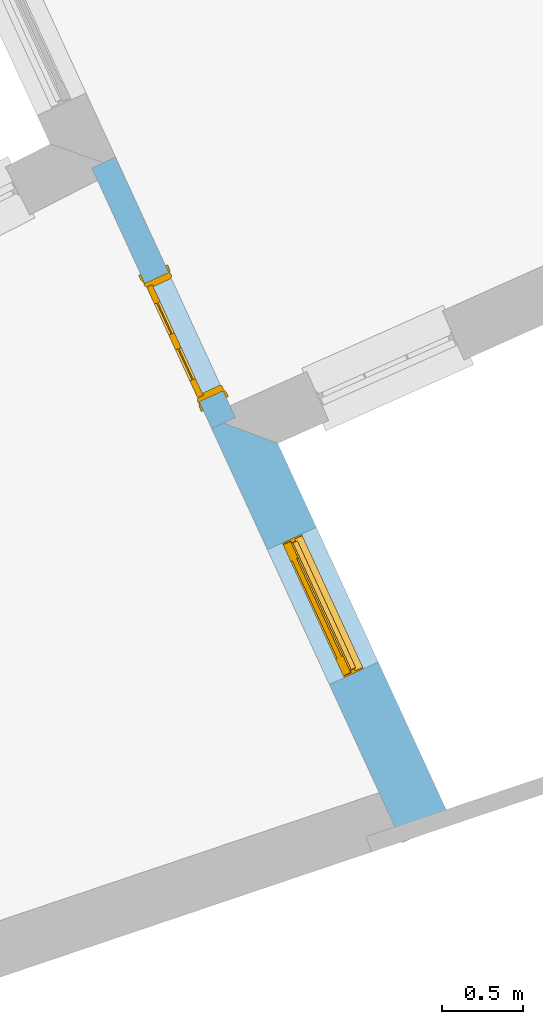
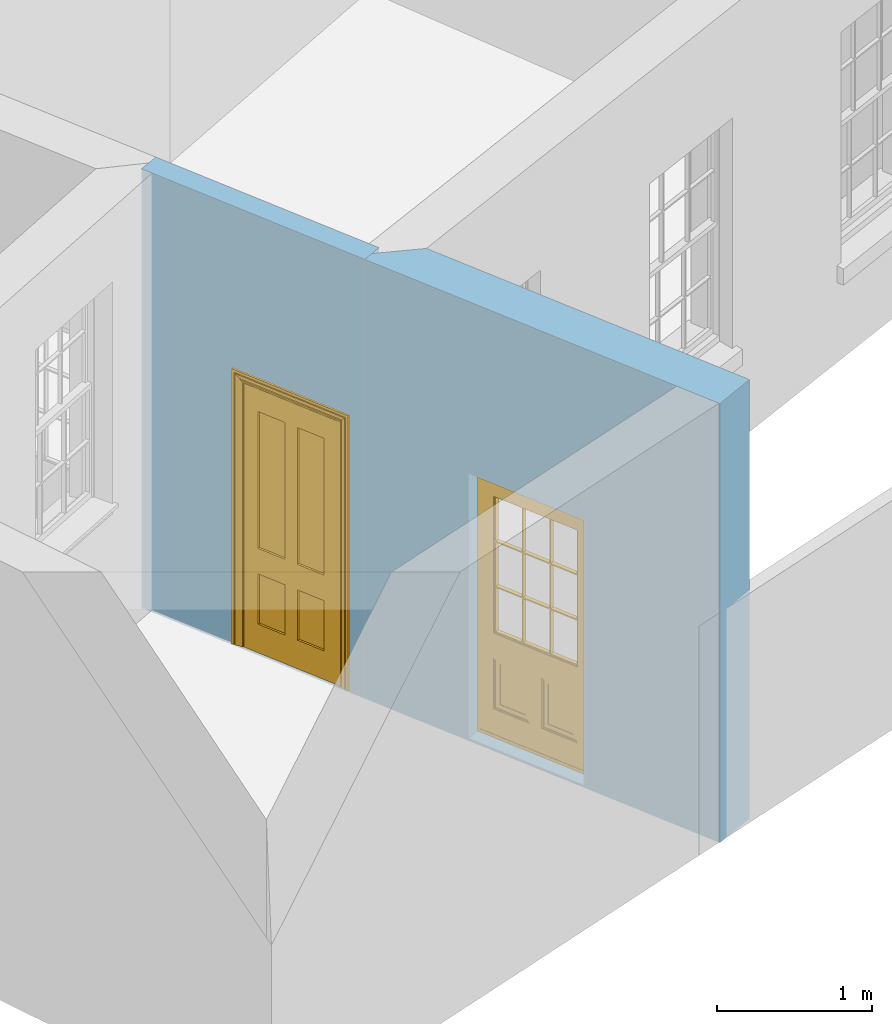
# One storey, part 3 of 10: 2 doors, 2 openings, plus 2 elements that do not belong to this part.
"""IFC2X3 building model written with IfcOpenShell, lengths in metres."""

from ifc_helpers import new_model, si_unit, frame, origin, place, context, subcontext, project, spatial, polyline, outline, extrude, faceted_brep, material, layer, layer_set, layer_usage, element, fill, save


model = new_model("IFC2X3")

# Units and contexts
model_context = context("Model", 3, world=origin())
body_context = subcontext(model_context, "Body", "Model", "MODEL_VIEW")
ifc_project = project(units=[si_unit("PLANEANGLEUNIT", "RADIAN"), si_unit("MASSUNIT", "GRAM", prefix="KILO"), si_unit("FORCEUNIT", "NEWTON", prefix="KILO"), si_unit("LENGTHUNIT", "METRE")], contexts=[model_context])

# Site, building, storey
site_placement = place(None, origin())
site = spatial("IfcSite", under=ifc_project, at=site_placement, CompositionType="ELEMENT")
building_placement = place(None, origin())
building = spatial("IfcBuilding", under=site, at=building_placement, Name="Building plot-8", CompositionType="ELEMENT")
storey_placement = place(None, origin())
storey = spatial("IfcBuildingStorey", under=building, at=storey_placement, Name="Floor 0", CompositionType="ELEMENT", Elevation=0.0)

# Wall, opening, door
ifc_material_1 = material(Name="Masonry")
ifc_layer_1 = layer(ifc_material_1, 0.33, ventilated=False)
ifc_layer_set_1 = layer_set([ifc_layer_1], Name="My Wall")
ifc_layer_usage_1 = layer_usage(ifc_layer_set_1, "AXIS2", "NEGATIVE", 0.08)
wall_1_placement = place(storey_placement, origin())
wall_1 = element("IfcWallStandardCase", 1, at=wall_1_placement, inside=storey, material=ifc_layer_usage_1, Name="exterior", context=body_context, shape_type="SweptSolid", body=[
    extrude(outline(polyline([(26.7463189204902, 6.45280484121041), (27.0461218313343, 6.59071138438159), (25.9819110894624, 8.90425989939787), (25.5427100949966, 9.06939881204675), (26.7463189204902, 6.45280484121041)])), origin(), (0.0, 0.0, 1.0), 3.45),
])
opening_1_placement = place(storey_placement, frame((0.0, 0.0, 0.02)))
opening_1 = element("IfcOpeningElement", 2, at=opening_1_placement, cuts=wall_1, Name="Opening", ObjectType="Opening", context=body_context, shape_type="SweptSolid", body=[
    extrude(outline(polyline([(26.5991206991673, 7.56247267643206), (26.2188329589074, 8.3892019154263), (25.9190300480633, 8.25129537225511), (26.2993177883233, 7.42456613326087), (26.5991206991673, 7.56247267643206)])), origin(), (0.0, 0.0, 1.0), 2.08),
])
door_1_placement = place(storey_placement, frame((26.3719972818612, 7.4579980225145, 0.02), z_axis=(0.0, 0.0, 1.0), x_axis=(-0.380287740259931, 0.82672923899424, 0.0)))
door_1 = element("IfcDoor", 3, at=door_1_placement, inside=storey, Name="kitchen door", OverallHeight=2.08, OverallWidth=0.91, context=body_context, shape_type="Brep", held_by="IfcProductRepresentation", body=[
    faceted_brep([(0.545, -0.055, 0.265), (0.745, -0.055, 0.265), (0.745, -0.05, 0.265), (0.545, -0.05, 0.265), (0.745, -0.05, 0.58), (0.545, -0.05, 0.58), (0.545, -0.055, 0.58), (0.515, -0.06, 0.235), (0.775, -0.06, 0.235), (0.745, -0.055, 0.58), (0.515, -0.06, 0.61), (0.515, -0.065, 0.235), (0.775, -0.065, 0.235), (0.775, -0.06, 0.61), (0.515, -0.065, 0.61), (0.785, -0.065, 0.225), (0.505, -0.065, 0.225), (0.775, -0.065, 0.61), (0.505, -0.065, 0.62), (0.785, -0.065, 0.62), (0.505, -0.07, 0.225), (0.785, -0.07, 0.225), (0.505, -0.07, 0.62), (0.785, -0.07, 0.62), (0.883, -0.07, 0.075), (0.898, -0.07, 0.075), (0.405, -0.07, 0.62), (0.405, -0.07, 0.225), (0.027, -0.07, 0.075), (0.785, -0.07, 0.82), (0.125, -0.07, 0.82), (0.405, -0.065, 0.62), (0.405, -0.065, 0.225), (0.898, -0.07, 2.068), (0.027, -0.08, 0.075), (0.883, -0.08, 0.075), (0.125, -0.07, 0.225), (0.012, -0.07, 0.075), (0.785, -0.06, 0.82), (0.125, -0.06, 0.82), (0.125, -0.07, 0.62), (0.125, -0.065, 0.62), (0.395, -0.065, 0.61), (0.395, -0.065, 0.235), (0.125, -0.065, 0.225), (0.785, -0.07, 1.895), (0.027, -0.11, 0.045), (0.883, -0.11, 0.045), (0.558333, -0.06, 0.83), (0.351667, -0.06, 0.83), (0.125, -0.07, 1.895), (0.125, -0.06, 1.895), (0.785, -0.06, 1.895), (0.012, -0.07, 2.068), (0.135, -0.065, 0.61), (0.395, -0.06, 0.61), (0.395, -0.06, 0.235), (0.135, -0.065, 0.235), (0.027, -0.11, 0.027), (0.883, -0.11, 0.027), (0.568333, -0.06, 0.83), (0.558333, -0.03, 0.83), (0.351667, -0.03, 0.83), (0.341667, -0.06, 0.83), (0.135, -0.06, 1.185), (0.135, -0.06, 1.53), (0.775, -0.06, 1.53), (0.775, -0.06, 1.185), (0.135, -0.06, 0.61), (0.365, -0.055, 0.58), (0.365, -0.055, 0.265), (0.135, -0.06, 0.235), (0.568333, -0.06, 1.175), (0.558333, -0.06, 1.175), (0.775, -0.06, 0.83), (0.558333, -0.03, 1.175), (0.785, -0.03, 0.82), (0.125, -0.03, 0.82), (0.351667, -0.03, 1.175), (0.351667, -0.06, 1.175), (0.341667, -0.06, 1.175), (0.135, -0.06, 0.83), (0.135, -0.06, 1.175), (0.135, -0.03, 1.185), (0.135, -0.03, 1.53), (0.135, -0.06, 1.54), (0.351667, -0.06, 1.885), (0.558333, -0.06, 1.885), (0.775, -0.03, 1.53), (0.775, -0.03, 1.185), (0.775, -0.06, 1.175), (0.775, -0.06, 1.54), (0.165, -0.055, 0.58), (0.365, -0.05, 0.58), (0.365, -0.05, 0.265), (0.165, -0.055, 0.265), (0.568333, -0.03, 0.83), (0.568333, -0.03, 1.175), (0.568333, -0.06, 1.185), (0.558333, -0.06, 1.185), (0.775, -0.03, 0.83), (0.785, -0.02, 0.82), (0.125, -0.02, 0.82), (0.341667, -0.03, 0.83), (0.341667, -0.03, 1.175), (0.351667, -0.06, 1.185), (0.341667, -0.06, 1.185), (0.135, -0.03, 0.83), (0.341667, -0.03, 1.185), (0.125, -0.03, 1.895), (0.341667, -0.03, 1.53), (0.341667, -0.06, 1.53), (0.135, -0.06, 1.885), (0.341667, -0.06, 1.54), (0.341667, -0.06, 1.885), (0.558333, -0.03, 1.885), (0.351667, -0.03, 1.885), (0.568333, -0.06, 1.885), (0.785, -0.03, 1.895), (0.568333, -0.03, 1.185), (0.568333, -0.06, 1.53), (0.568333, -0.03, 1.53), (0.568333, -0.06, 1.54), (0.775, -0.06, 1.885), (0.165, -0.05, 0.58), (0.165, -0.05, 0.265), (0.775, -0.03, 1.175), (0.558333, -0.06, 1.53), (0.351667, -0.03, 1.185), (0.558333, -0.03, 1.185), (0.505, -0.02, 0.62), (0.405, -0.02, 0.62), (0.125, -0.02, 1.895), (0.785, -0.02, 1.895), (0.351667, -0.06, 1.53), (0.135, -0.03, 1.175), (0.135, -0.03, 1.54), (0.341667, -0.03, 1.54), (0.135, -0.03, 1.885), (0.351667, -0.06, 1.54), (0.558333, -0.03, 1.54), (0.558333, -0.06, 1.54), (0.351667, -0.03, 1.54), (0.775, -0.03, 1.54), (0.568333, -0.03, 1.54), (0.775, -0.03, 1.885), (0.558333, -0.03, 1.53), (0.405, -0.02, 0.225), (0.505, -0.02, 0.225), (0.125, -0.02, 0.62), (0.785, -0.02, 0.62), (0.012, -0.02, 2.068), (0.898, -0.02, 2.068), (0.351667, -0.03, 1.53), (0.341667, -0.03, 1.885), (0.568333, -0.03, 1.885), (0.405, -0.025, 0.225), (0.405, -0.025, 0.62), (0.505, -0.025, 0.62), (0.505, -0.025, 0.225), (0.898, -0.02, 0.027), (0.012, -0.02, 0.027), (0.125, -0.025, 0.62), (0.785, -0.025, 0.62), (0.395, -0.025, 0.235), (0.395, -0.025, 0.61), (0.125, -0.02, 0.225), (0.125, -0.025, 0.225), (0.515, -0.025, 0.61), (0.515, -0.025, 0.235), (0.785, -0.02, 0.225), (0.785, -0.025, 0.225), (0.135, -0.025, 0.61), (0.775, -0.025, 0.61), (0.135, -0.025, 0.235), (0.395, -0.03, 0.235), (0.395, -0.03, 0.61), (0.515, -0.03, 0.61), (0.515, -0.03, 0.235), (0.775, -0.025, 0.235), (0.135, -0.03, 0.61), (0.775, -0.03, 0.61), (0.135, -0.03, 0.235), (0.365, -0.035, 0.265), (0.365, -0.035, 0.58), (0.545, -0.035, 0.58), (0.545, -0.035, 0.265), (0.775, -0.03, 0.235), (0.165, -0.035, 0.58), (0.745, -0.035, 0.58), (0.165, -0.035, 0.265), (0.365, -0.04, 0.58), (0.365, -0.04, 0.265), (0.545, -0.04, 0.58), (0.545, -0.04, 0.265), (0.745, -0.035, 0.265), (0.165, -0.04, 0.58), (0.745, -0.04, 0.58), (0.165, -0.04, 0.265), (0.745, -0.04, 0.265), (0.885, -0.072, 0.025), (0.025, -0.072, 0.025), (0.025, -0.1, 0.025), (0.885, -0.1, 0.025), (0.9, -0.02, 0.025), (0.01, -0.02, 0.025), (0.9, -0.072, 0.025), (0.91, -0.02, 0.0), (0.0, -0.02, 0.0), (0.01, -0.072, 0.025), (0.9, -0.072, 2.07), (0.9, -0.02, 2.07), (0.885, -0.072, 2.055), (0.91, -0.02, 2.08), (0.01, -0.02, 2.07), (0.0, -0.02, 2.08), (0.01, -0.072, 2.07), (0.025, -0.072, 2.055), (0.0, -0.15, 2.08), (0.91, -0.15, 2.08), (0.01, -0.15, 2.07), (0.9, -0.15, 2.07), (0.01, -0.1, 2.07), (0.9, -0.1, 2.07), (0.0, -0.15, 0.0), (0.91, -0.15, 0.0), (0.01, -0.15, 0.025), (0.9, -0.15, 0.025), (0.01, -0.1, 0.025), (0.025, -0.1, 2.055), (0.9, -0.1, 0.025), (0.885, -0.1, 2.055), (0.898, -0.07, 0.027), (0.012, -0.07, 0.027), (0.883, -0.07, 0.027), (0.027, -0.07, 0.027)], [[[0, 1, 2, 3]], [[2, 4, 5, 3]], [[0, 3, 5, 6]], [[1, 0, 7, 8]], [[9, 4, 2, 1]], [[9, 6, 5, 4]], [[0, 6, 10, 7]], [[8, 7, 11, 12]], [[8, 13, 9, 1]], [[13, 10, 6, 9]], [[7, 10, 14, 11]], [[15, 12, 11, 16]], [[12, 17, 13, 8]], [[17, 14, 10, 13]], [[18, 16, 11, 14]], [[15, 19, 17, 12]], [[15, 16, 20, 21]], [[14, 17, 19, 18]], [[16, 18, 22, 20]], [[21, 23, 19, 15]], [[24, 25, 21, 20]], [[23, 22, 18, 19]], [[20, 22, 26, 27]], [[23, 21, 25]], [[28, 24, 20, 27]], [[22, 23, 29]], [[29, 30, 26, 22]], [[27, 26, 31, 32]], [[23, 25, 33, 29]], [[34, 35, 24, 28]], [[28, 27, 36, 37]], [[38, 39, 30, 29]], [[26, 30, 40]], [[26, 40, 41, 31]], [[42, 43, 32, 31]], [[32, 44, 36, 27]], [[33, 45, 29]], [[46, 47, 35, 34]], [[36, 40, 37]], [[39, 38, 48, 49]], [[50, 30, 39, 51]], [[29, 45, 52, 38]], [[53, 37, 40, 30]], [[44, 41, 40, 36]], [[31, 41, 54, 42]], [[43, 42, 55, 56]], [[57, 44, 32, 43]], [[50, 45, 33, 53]], [[47, 46, 58, 59]], [[60, 48, 38]], [[49, 48, 61, 62]], [[49, 63, 39]], [[50, 53, 30]], [[51, 39, 64, 65]], [[45, 50, 51, 52]], [[66, 67, 38, 52]], [[57, 54, 41, 44]], [[42, 54, 68, 55]], [[56, 55, 69, 70]], [[56, 71, 57, 43]], [[60, 72, 73, 48]], [[60, 38, 74]], [[48, 73, 75, 61]], [[76, 77, 62, 61]], [[62, 78, 79, 49]], [[49, 79, 80, 63]], [[63, 81, 39]], [[82, 64, 39]], [[65, 64, 83, 84]], [[85, 51, 65]], [[52, 51, 86, 87]], [[88, 89, 67, 66]], [[90, 38, 67]], [[91, 66, 52]], [[71, 68, 54, 57]], [[55, 68, 92, 69]], [[69, 93, 94, 70]], [[70, 95, 71, 56]], [[96, 97, 72, 60]], [[73, 72, 98, 99]], [[74, 38, 90]], [[100, 96, 60, 74]], [[75, 73, 79, 78]], [[61, 75, 97, 96]], [[101, 102, 77, 76]], [[77, 103, 62]], [[96, 76, 61]], [[103, 104, 78, 62]], [[80, 79, 105, 106]], [[63, 80, 104, 103]], [[81, 63, 103, 107]], [[81, 82, 39]], [[106, 64, 82, 80]], [[106, 108, 83, 64]], [[84, 83, 77, 109]], [[110, 111, 65, 84]], [[112, 51, 85]], [[113, 85, 65, 111]], [[114, 86, 51]], [[115, 87, 86, 116]], [[117, 52, 87]], [[118, 76, 89, 88]], [[119, 98, 67, 89]], [[120, 121, 88, 66]], [[67, 98, 72, 90]], [[91, 122, 120, 66]], [[91, 52, 123]], [[95, 92, 68, 71]], [[69, 92, 124, 93]], [[94, 93, 124, 125]], [[94, 125, 95, 70]], [[72, 97, 126, 90]], [[127, 99, 98, 120]], [[99, 105, 79, 73]], [[74, 90, 126, 100]], [[96, 100, 76]], [[128, 129, 75, 78]], [[97, 75, 129, 119]], [[130, 131, 102, 101]], [[109, 77, 102, 132]], [[133, 101, 76, 118]], [[77, 107, 103]], [[78, 104, 108, 128]], [[111, 106, 105, 134]], [[104, 80, 82, 135]], [[107, 135, 82, 81]], [[110, 108, 106, 111]], [[104, 135, 83, 108]], [[83, 135, 77]], [[136, 84, 109]], [[110, 84, 136, 137]], [[114, 51, 112]], [[85, 136, 138, 112]], [[113, 137, 136, 85]], [[111, 134, 139, 113]], [[86, 114, 113, 139]], [[140, 141, 87, 115]], [[139, 142, 116, 86]], [[109, 118, 115, 116]], [[117, 123, 52]], [[117, 87, 141, 122]], [[126, 89, 76]], [[143, 118, 88]], [[120, 98, 119, 121]], [[119, 89, 126, 97]], [[144, 143, 88, 121]], [[144, 122, 91, 143]], [[127, 120, 122, 141]], [[143, 91, 123, 145]], [[124, 92, 95, 125]], [[146, 129, 99, 127]], [[99, 129, 128, 105]], [[100, 126, 76]], [[121, 119, 129, 146]], [[147, 131, 130, 148]], [[131, 149, 102]], [[130, 101, 150]], [[102, 151, 132]], [[118, 109, 132, 133]], [[101, 133, 152]], [[107, 77, 135]], [[153, 128, 108, 110]], [[134, 105, 128, 153]], [[109, 138, 136]], [[153, 110, 137, 142]], [[154, 114, 112, 138]], [[137, 113, 114, 154]], [[141, 139, 134, 127]], [[141, 140, 142, 139]], [[144, 140, 115, 155]], [[142, 137, 154, 116]], [[155, 115, 118]], [[116, 154, 109]], [[117, 155, 145, 123]], [[122, 144, 155, 117]], [[143, 145, 118]], [[121, 146, 140, 144]], [[146, 127, 134, 153]], [[156, 157, 131, 147]], [[148, 130, 158, 159]], [[148, 160, 161, 147]], [[157, 162, 149, 131]], [[161, 151, 102, 149]], [[101, 152, 160, 150]], [[163, 158, 130, 150]], [[151, 152, 133, 132]], [[154, 138, 109]], [[142, 140, 146, 153]], [[145, 155, 118]], [[157, 156, 164, 165]], [[147, 166, 167, 156]], [[168, 169, 159, 158]], [[170, 148, 159, 171]], [[148, 170, 160]], [[166, 147, 161]], [[172, 162, 157, 165]], [[166, 149, 162, 167]], [[166, 161, 149]], [[150, 160, 170]], [[163, 173, 168, 158]], [[171, 163, 150, 170]], [[174, 164, 156, 167]], [[175, 176, 165, 164]], [[169, 168, 177, 178]], [[171, 159, 169, 179]], [[167, 162, 172, 174]], [[176, 180, 172, 165]], [[179, 173, 163, 171]], [[181, 177, 168, 173]], [[164, 174, 182, 175]], [[183, 184, 176, 175]], [[178, 177, 185, 186]], [[179, 169, 178, 187]], [[174, 172, 180, 182]], [[184, 188, 180, 176]], [[187, 181, 173, 179]], [[189, 185, 177, 181]], [[175, 182, 190, 183]], [[191, 184, 183, 192]], [[185, 193, 194, 186]], [[187, 178, 186, 195]], [[182, 180, 188, 190]], [[191, 196, 188, 184]], [[195, 189, 181, 187]], [[197, 193, 185, 189]], [[183, 190, 198, 192]], [[198, 196, 191, 192]], [[194, 193, 197, 199]], [[195, 186, 194, 199]], [[188, 196, 198, 190]], [[197, 189, 195, 199]], [[200, 201, 202, 203]], [[201, 200, 204, 205]], [[206, 204, 200]], [[204, 207, 208, 205]], [[209, 201, 205]], [[210, 211, 204, 206]], [[206, 200, 212, 210]], [[211, 213, 207, 204]], [[214, 205, 208, 215]], [[216, 217, 201, 209]], [[205, 214, 216, 209]], [[216, 214, 211, 210]], [[210, 212, 217, 216]], [[214, 215, 213, 211]], [[218, 219, 213, 215]], [[219, 218, 220, 221]], [[221, 220, 222, 223]], [[215, 208, 224, 218]], [[225, 224, 208, 207]], [[224, 226, 220, 218]], [[224, 225, 227, 226]], [[219, 225, 207, 213]], [[228, 222, 220, 226]], [[219, 221, 227, 225]], [[226, 227, 203, 202]], [[202, 229, 222, 228]], [[228, 226, 202]], [[227, 221, 223, 230]], [[230, 203, 227]], [[217, 229, 202, 201]], [[231, 223, 222, 229]], [[230, 223, 231, 203]], [[231, 229, 217, 212]], [[212, 200, 203, 231]], [[33, 152, 151, 53]], [[25, 160, 152, 33]], [[161, 37, 53, 151]], [[232, 160, 25]], [[161, 233, 37]], [[160, 232, 234]], [[24, 234, 232, 25]], [[233, 161, 235]], [[37, 233, 235, 28]], [[161, 160, 234, 235]], [[35, 47, 234, 24]], [[28, 235, 46, 34]], [[58, 235, 234, 59]], [[59, 234, 47]], [[58, 46, 235]]]),
])
fill(opening_1, door_1)

ifc_material_2 = material(Name="Masonry")
ifc_layer_2 = layer(ifc_material_2, 0.16, ventilated=False)
ifc_layer_set_2 = layer_set([ifc_layer_2], Name="My Wall")
ifc_layer_usage_2 = layer_usage(ifc_layer_set_2, "AXIS2", "NEGATIVE", 0.08)
wall_2_placement = place(storey_placement, origin())
wall_2 = element("IfcWallStandardCase", 4, at=wall_2_placement, inside=storey, material=ifc_layer_usage_2, Name="interior", context=body_context, shape_type="SweptSolid", body=[
    extrude(outline(polyline([(25.5765035698139, 8.99593324699947), (25.7218625568899, 9.06279702550671), (24.9867751738983, 10.6608454725049), (24.8414161868223, 10.5939816939977), (25.5765035698139, 8.99593324699947)])), origin(), (0.0, 0.0, 1.0), 3.45),
])
opening_2_placement = place(storey_placement, frame((0.0, 0.0, 0.02)))
opening_2 = element("IfcOpeningElement", 5, at=opening_2_placement, cuts=wall_2, Name="Opening", ObjectType="Opening", context=body_context, shape_type="SweptSolid", body=[
    extrude(outline(polyline([(25.6466408060692, 9.22632588596711), (25.312321913533, 9.95312082134665), (25.1669629264571, 9.8862570428394), (25.5012818189933, 9.15946210745986), (25.6466408060692, 9.22632588596711)])), origin(), (0.0, 0.0, 1.0), 2.1),
])
door_2_placement = place(storey_placement, frame((25.5739613125312, 9.19289399671348, 0.02), z_axis=(0.0, 0.0, 1.0), x_axis=(-0.334318892536235, 0.726794935379537, 0.0)))
door_2 = element("IfcDoor", 6, at=door_2_placement, inside=storey, Name="kitchen living inside door", OverallHeight=2.1, OverallWidth=0.8, context=body_context, shape_type="Brep", held_by="IfcProductRepresentation", body=[
    faceted_brep([(0.773, 0.08, 1.895), (0.66, 0.08, 1.895), (0.66, 0.08, 2.073), (0.773, 0.08, 2.073), (0.773, 0.08, 0.82), (0.66, 0.08, 0.82), (0.45, 0.08, 1.895), (0.45, 0.08, 2.073), (0.773, 0.08, 0.62), (0.66, 0.08, 0.62), (0.66, 0.065, 0.82), (0.66, 0.065, 1.895), (0.45, 0.065, 1.895), (0.35, 0.08, 1.895), (0.35, 0.08, 2.073), (0.773, 0.08, 0.225), (0.66, 0.08, 0.225), (0.45, 0.08, 0.62), (0.45, 0.08, 0.82), (0.45, 0.065, 0.82), (0.35, 0.08, 0.82), (0.14, 0.08, 2.073), (0.14, 0.08, 1.895), (0.773, 0.08, 0.0), (0.66, 0.08, 0.0), (0.66, 0.065, 0.225), (0.66, 0.065, 0.62), (0.45, 0.065, 0.62), (0.35, 0.08, 0.62), (0.35, 0.065, 0.82), (0.35, 0.065, 1.895), (0.14, 0.065, 1.895), (0.027, 0.08, 2.073), (0.027, 0.08, 1.895), (0.773, 0.042, 0.0), (0.66, 0.042, 0.0), (0.45, 0.08, 0.0), (0.45, 0.08, 0.225), (0.45, 0.065, 0.225), (0.35, 0.08, 0.225), (0.14, 0.08, 0.82), (0.14, 0.08, 0.62), (0.14, 0.065, 0.82), (0.027, 0.08, 0.82), (0.773, 0.042, 0.225), (0.66, 0.042, 0.225), (0.45, 0.042, 0.0), (0.35, 0.08, 0.0), (0.35, 0.065, 0.225), (0.35, 0.065, 0.62), (0.14, 0.065, 0.62), (0.027, 0.08, 0.62), (0.773, 0.042, 0.62), (0.66, 0.042, 0.62), (0.45, 0.042, 0.225), (0.35, 0.042, 0.0), (0.14, 0.08, 0.225), (0.14, 0.08, 0.0), (0.14, 0.065, 0.225), (0.027, 0.08, 0.225), (0.773, 0.042, 0.82), (0.66, 0.042, 0.82), (0.66, 0.057, 0.62), (0.66, 0.057, 0.225), (0.45, 0.057, 0.225), (0.35, 0.042, 0.225), (0.14, 0.042, 0.0), (0.027, 0.08, 0.0), (0.773, 0.042, 1.895), (0.66, 0.042, 1.895), (0.45, 0.042, 0.62), (0.45, 0.042, 0.82), (0.45, 0.057, 0.62), (0.35, 0.042, 0.62), (0.14, 0.042, 0.225), (0.027, 0.042, 0.0), (0.773, 0.042, 2.073), (0.66, 0.042, 2.073), (0.66, 0.057, 1.895), (0.66, 0.057, 0.82), (0.45, 0.057, 0.82), (0.35, 0.042, 0.82), (0.35, 0.057, 0.62), (0.35, 0.057, 0.225), (0.14, 0.057, 0.225), (0.027, 0.042, 0.225), (0.45, 0.042, 1.895), (0.45, 0.042, 2.073), (0.45, 0.057, 1.895), (0.35, 0.042, 1.895), (0.14, 0.042, 0.82), (0.14, 0.042, 0.62), (0.14, 0.057, 0.62), (0.027, 0.042, 0.62), (0.35, 0.042, 2.073), (0.35, 0.057, 1.895), (0.35, 0.057, 0.82), (0.14, 0.057, 0.82), (0.027, 0.042, 0.82), (0.14, 0.042, 2.073), (0.14, 0.042, 1.895), (0.14, 0.057, 1.895), (0.027, 0.042, 1.895), (0.027, 0.042, 2.073), (0.02, 0.085, 0.0), (0.005, 0.09, 0.0), (0.005, 0.09, 2.095), (0.02, 0.085, 2.08), (0.02, 0.08, 0.0), (0.0, 0.085, 0.0), (0.0, 0.085, 2.1), (0.795, 0.09, 2.095), (0.78, 0.085, 2.08), (0.02, 0.08, 2.08), (0.0, 0.08, 0.0), (-0.032, 0.095, 0.0), (-0.032, 0.095, 2.132), (0.8, 0.085, 2.1), (0.795, 0.09, 0.0), (0.78, 0.085, 0.0), (0.78, 0.08, 2.08), (0.04, 0.04, 0.0), (0.025, 0.04, 0.0), (0.025, 0.04, 2.075), (0.04, 0.04, 2.06), (-0.04, 0.09, 0.0), (-0.04, 0.09, 2.14), (0.832, 0.095, 2.132), (0.8, 0.085, 0.0), (0.78, 0.08, 0.0), (0.8, 0.08, 0.0), (0.86, 0.08, 0.0), (0.86, 0.08, 2.16), (0.8, 0.08, 2.1), (-0.06, 0.08, 2.16), (0.0, 0.08, 2.1), (-0.06, 0.08, 0.0), (-0.04, 0.095, 0.0), (-0.04, 0.095, 2.14), (0.84, 0.09, 2.14), (0.832, 0.095, 0.0), (0.84, 0.09, 0.0), (0.86, 0.095, 0.0), (0.86, 0.095, 2.16), (-0.06, 0.095, 2.16), (-0.06, 0.095, 0.0), (0.84, 0.095, 0.0), (0.84, 0.095, 2.14), (-0.025, -0.095, 0.0), (-0.025, -0.09, 0.0), (-0.025, -0.09, 2.125), (-0.025, -0.095, 2.125), (-0.017, -0.095, 0.0), (-0.017, -0.095, 2.117), (0.825, -0.09, 2.125), (0.825, -0.095, 2.125), (0.825, -0.095, 0.0), (0.845, -0.095, 0.0), (-0.045, -0.095, 2.145), (-0.045, -0.095, 0.0), (0.845, -0.095, 2.145), (0.015, -0.085, 0.0), (0.015, -0.085, 2.085), (0.817, -0.095, 2.117), (0.825, -0.09, 0.0), (0.845, -0.08, 0.0), (0.845, -0.08, 2.145), (-0.045, -0.08, 2.145), (-0.045, -0.08, 0.0), (0.02, -0.09, 0.0), (0.02, -0.09, 2.08), (0.785, -0.085, 2.085), (0.817, -0.095, 0.0), (0.8, -0.08, 0.0), (0.8, -0.08, 2.1), (0.0, -0.08, 2.1), (0.0, -0.08, 0.0), (0.035, -0.085, 0.0), (0.035, -0.085, 2.065), (0.78, -0.09, 2.08), (0.785, -0.085, 0.0), (0.775, 0.04, 2.075), (0.76, 0.04, 2.06), (0.035, -0.08, 2.065), (0.035, -0.08, 0.0), (0.765, -0.085, 2.065), (0.78, -0.09, 0.0), (0.765, -0.08, 0.0), (0.765, -0.08, 2.065), (0.765, -0.085, 0.0), (0.04, -0.08, 2.06), (0.04, -0.08, 0.0), (0.76, -0.08, 2.06), (0.76, -0.08, 0.0), (0.76, 0.04, 0.0), (0.775, 0.04, 0.0), (0.025, 0.08, 0.0), (0.025, 0.08, 2.075), (0.775, 0.08, 0.0), (0.775, 0.08, 2.075)], [[[0, 1, 2, 3]], [[1, 0, 4, 5]], [[1, 6, 7, 2]], [[8, 9, 5, 4]], [[1, 5, 10, 11]], [[6, 1, 11, 12]], [[6, 13, 14, 7]], [[15, 16, 9, 8]], [[9, 17, 18, 5]], [[5, 18, 19, 10]], [[10, 19, 12, 11]], [[18, 6, 12, 19]], [[18, 20, 13, 6]], [[21, 14, 13, 22]], [[23, 24, 16, 15]], [[9, 16, 25, 26]], [[17, 9, 26, 27]], [[17, 28, 20, 18]], [[13, 20, 29, 30]], [[22, 13, 30, 31]], [[32, 21, 22, 33]], [[34, 35, 24, 23]], [[24, 36, 37, 16]], [[16, 37, 38, 25]], [[25, 38, 27, 26]], [[37, 17, 27, 38]], [[37, 39, 28, 17]], [[40, 20, 28, 41]], [[20, 40, 42, 29]], [[31, 30, 29, 42]], [[40, 22, 31, 42]], [[33, 22, 40, 43]], [[35, 34, 44, 45]], [[35, 46, 36, 24]], [[36, 47, 39, 37]], [[28, 39, 48, 49]], [[41, 28, 49, 50]], [[43, 40, 41, 51]], [[45, 44, 52, 53]], [[46, 35, 45, 54]], [[46, 55, 47, 36]], [[56, 39, 47, 57]], [[39, 56, 58, 48]], [[50, 49, 48, 58]], [[56, 41, 50, 58]], [[51, 41, 56, 59]], [[53, 52, 60, 61]], [[45, 53, 62, 63]], [[54, 45, 63, 64]], [[55, 46, 54, 65]], [[55, 66, 57, 47]], [[59, 56, 57, 67]], [[61, 60, 68, 69]], [[70, 53, 61, 71]], [[53, 70, 72, 62]], [[72, 64, 63, 62]], [[70, 54, 64, 72]], [[65, 54, 70, 73]], [[65, 74, 66, 55]], [[67, 57, 66, 75]], [[69, 68, 76, 77]], [[61, 69, 78, 79]], [[71, 61, 79, 80]], [[73, 70, 71, 81]], [[65, 73, 82, 83]], [[74, 65, 83, 84]], [[74, 85, 75, 66]], [[86, 69, 77, 87]], [[69, 86, 88, 78]], [[88, 80, 79, 78]], [[86, 71, 80, 88]], [[81, 71, 86, 89]], [[73, 81, 90, 91]], [[73, 91, 92, 82]], [[83, 82, 92, 84]], [[91, 74, 84, 92]], [[91, 93, 85, 74]], [[89, 86, 87, 94]], [[81, 89, 95, 96]], [[90, 81, 96, 97]], [[90, 98, 93, 91]], [[94, 99, 100, 89]], [[89, 100, 101, 95]], [[101, 97, 96, 95]], [[100, 90, 97, 101]], [[100, 102, 98, 90]], [[99, 103, 102, 100]], [[32, 103, 99, 21]], [[102, 103, 32, 33]], [[98, 102, 33, 43]], [[21, 99, 94, 14]], [[94, 87, 7, 14]], [[7, 87, 77, 2]], [[76, 3, 2, 77]], [[43, 51, 93, 98]], [[51, 59, 85, 93]], [[67, 75, 85, 59]], [[34, 23, 15, 44]], [[44, 15, 8, 52]], [[52, 8, 4, 60]], [[0, 68, 60, 4]], [[0, 3, 76, 68]], [[104, 105, 106, 107]], [[104, 108, 109, 105]], [[105, 109, 110, 106]], [[107, 106, 111, 112]], [[107, 113, 108, 104]], [[114, 109, 108]], [[109, 115, 116, 110]], [[106, 110, 117, 111]], [[112, 111, 118, 119]], [[113, 107, 112, 120]], [[121, 122, 123, 124]], [[115, 109, 114, 125]], [[115, 125, 126, 116]], [[110, 116, 127, 117]], [[111, 117, 128, 118]], [[118, 128, 129, 119]], [[120, 112, 119, 129]], [[130, 129, 128]], [[130, 131, 132, 133]], [[133, 132, 134, 135]], [[135, 134, 136, 114]], [[136, 125, 114]], [[125, 137, 138, 126]], [[116, 126, 139, 127]], [[117, 127, 140, 128]], [[141, 130, 128, 140]], [[131, 130, 141]], [[131, 142, 143, 132]], [[132, 143, 144, 134]], [[134, 144, 145, 136]], [[137, 125, 136, 145]], [[143, 142, 146]], [[143, 146, 147]], [[137, 145, 144]], [[143, 147, 138]], [[138, 137, 144]], [[143, 138, 144]], [[126, 138, 147, 139]], [[127, 139, 141, 140]], [[142, 131, 141, 146]], [[139, 147, 146, 141]], [[148, 149, 150, 151]], [[149, 152, 153, 150]], [[151, 150, 154, 155]], [[155, 156, 157]], [[158, 159, 148]], [[158, 148, 151]], [[155, 157, 160]], [[158, 151, 155]], [[155, 160, 158]], [[152, 161, 162, 153]], [[150, 153, 163, 154]], [[155, 154, 164, 156]], [[156, 164, 165, 157]], [[157, 165, 166, 160]], [[160, 166, 167, 158]], [[158, 167, 168, 159]], [[161, 169, 170, 162]], [[153, 162, 171, 163]], [[154, 163, 172, 164]], [[165, 164, 173]], [[165, 173, 174, 166]], [[166, 174, 175, 167]], [[167, 175, 176, 168]], [[169, 177, 178, 170]], [[162, 170, 179, 171]], [[163, 171, 180, 172]], [[172, 180, 173, 164]], [[124, 123, 181, 182]], [[183, 178, 177, 184]], [[170, 178, 185, 179]], [[171, 179, 186, 180]], [[187, 173, 180]], [[185, 188, 187, 189]], [[188, 185, 178, 183]], [[179, 185, 189, 186]], [[189, 187, 180, 186]], [[190, 183, 184, 191]], [[192, 188, 183, 190]], [[191, 184, 122, 121]], [[124, 190, 191, 121]], [[193, 187, 188, 192]], [[182, 192, 190, 124]], [[184, 176, 122]], [[194, 195, 187, 193]], [[192, 182, 194, 193]], [[161, 176, 184]], [[114, 108, 122, 176]], [[173, 187, 195]], [[152, 149, 176, 161]], [[169, 161, 184, 177]], [[196, 122, 108]], [[176, 175, 135, 114]], [[173, 195, 129, 130]], [[176, 149, 168]], [[123, 122, 196, 197]], [[196, 108, 113, 197]], [[175, 174, 133, 135]], [[198, 129, 195]], [[133, 174, 173, 130]], [[159, 168, 149, 148]], [[181, 123, 197, 199]], [[197, 113, 120, 199]], [[199, 120, 129, 198]], [[195, 181, 199, 198]], [[195, 194, 182, 181]]]),
])
fill(opening_2, door_2)

save(model, "model.ifc")
